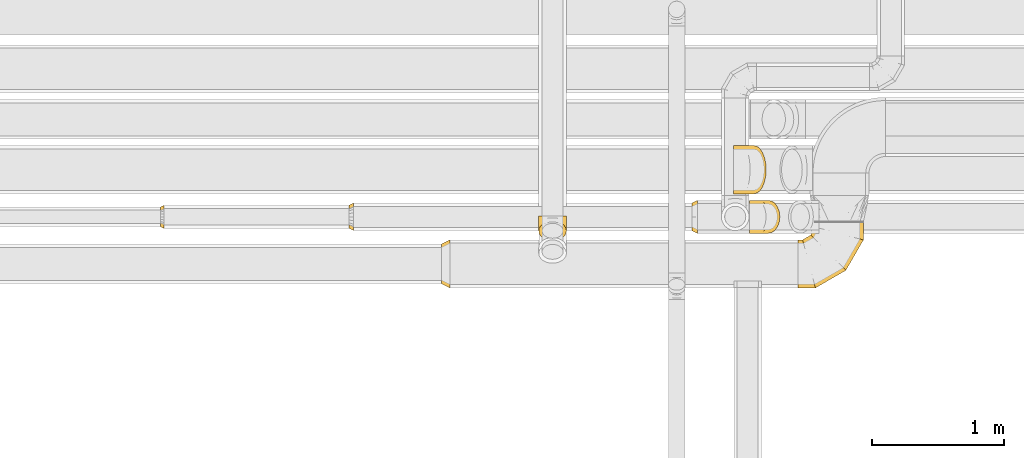
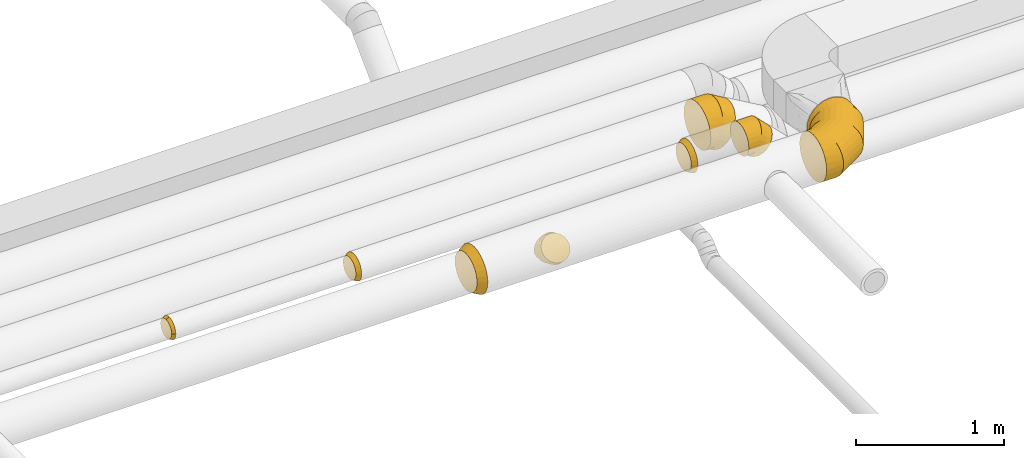
# One storey, part 17 of 92: 8 coverings.
"""IFC2X3 building model written with IfcOpenShell, lengths in millimetres."""

from ifc_helpers import new_model, entity, si_unit, converted_unit, derived_unit, direction, frame, origin, place, context, subcontext, project, spatial, faceted_brep, element, save


model = new_model("IFC2X3")

# Units and contexts
model_context = context("Model", 3, precision=0.01, world=origin(), true_north=direction((6.12303176911189e-17, 1.0)))
body_context = subcontext(model_context, "Body", "Model", "MODEL_VIEW")
ifc_project = project(units=[si_unit("LENGTHUNIT", "METRE", prefix="MILLI"), si_unit("AREAUNIT", "SQUARE_METRE"), si_unit("VOLUMEUNIT", "CUBIC_METRE"), converted_unit("PLANEANGLEUNIT", "DEGREE", entity("IfcRatioMeasure", 0.0174532925199433), si_unit("PLANEANGLEUNIT", "RADIAN"), dimensions=[0, 0, 0, 0, 0, 0, 0]), si_unit("MASSUNIT", "GRAM", prefix="KILO"), derived_unit("MASSDENSITYUNIT", [(si_unit("MASSUNIT", "GRAM", prefix="KILO"), 1), (si_unit("LENGTHUNIT", "METRE"), -3)]), derived_unit("MOMENTOFINERTIAUNIT", [(si_unit("LENGTHUNIT", "METRE"), 4)]), si_unit("TIMEUNIT", "SECOND"), si_unit("FREQUENCYUNIT", "HERTZ"), si_unit("THERMODYNAMICTEMPERATUREUNIT", "DEGREE_CELSIUS"), derived_unit("THERMALTRANSMITTANCEUNIT", [(si_unit("MASSUNIT", "GRAM", prefix="KILO"), 1), (si_unit("THERMODYNAMICTEMPERATUREUNIT", "KELVIN"), -1), (si_unit("TIMEUNIT", "SECOND"), -3)]), derived_unit("VOLUMETRICFLOWRATEUNIT", [(si_unit("LENGTHUNIT", "METRE"), 3), (si_unit("TIMEUNIT", "SECOND"), -1)]), derived_unit("MASSFLOWRATEUNIT", [(si_unit("MASSUNIT", "GRAM", prefix="KILO"), 1), (si_unit("TIMEUNIT", "SECOND"), -1)]), derived_unit("ROTATIONALFREQUENCYUNIT", [(si_unit("TIMEUNIT", "SECOND"), -1)]), si_unit("ELECTRICCURRENTUNIT", "AMPERE"), si_unit("ELECTRICVOLTAGEUNIT", "VOLT"), si_unit("POWERUNIT", "WATT"), si_unit("FORCEUNIT", "NEWTON", prefix="KILO"), si_unit("ILLUMINANCEUNIT", "LUX"), si_unit("LUMINOUSFLUXUNIT", "LUMEN"), si_unit("LUMINOUSINTENSITYUNIT", "CANDELA"), derived_unit("USERDEFINED", [(si_unit("MASSUNIT", "GRAM", prefix="KILO"), -1), (si_unit("LENGTHUNIT", "METRE"), -2), (si_unit("TIMEUNIT", "SECOND"), 3), (si_unit("LUMINOUSFLUXUNIT", "LUMEN"), 1)]), derived_unit("LINEARVELOCITYUNIT", [(si_unit("LENGTHUNIT", "METRE"), 1), (si_unit("TIMEUNIT", "SECOND"), -1)]), si_unit("PRESSUREUNIT", "PASCAL"), derived_unit("USERDEFINED", [(si_unit("LENGTHUNIT", "METRE"), -2), (si_unit("MASSUNIT", "GRAM", prefix="KILO"), 1), (si_unit("TIMEUNIT", "SECOND"), -2)]), derived_unit("LINEARFORCEUNIT", [(si_unit("MASSUNIT", "GRAM", prefix="KILO"), 1), (si_unit("LENGTHUNIT", "METRE"), 1), (si_unit("TIMEUNIT", "SECOND"), -2), (si_unit("LENGTHUNIT", "METRE"), -1)]), derived_unit("PLANARFORCEUNIT", [(si_unit("MASSUNIT", "GRAM", prefix="KILO"), 1), (si_unit("LENGTHUNIT", "METRE"), 1), (si_unit("TIMEUNIT", "SECOND"), -2), (si_unit("LENGTHUNIT", "METRE"), -2)])], contexts=[model_context])

# Site, building, storey
site_placement = place(None, origin())
site = spatial("IfcSite", under=ifc_project, at=site_placement, CompositionType="ELEMENT")
building_placement = place(site_placement, origin())
building = spatial("IfcBuilding", under=site, at=building_placement, CompositionType="ELEMENT")
storey_placement = place(building_placement, frame((0.0, 0.0, 4200.0)))
storey = spatial("IfcBuildingStorey", under=building, at=storey_placement, CompositionType="ELEMENT", Elevation=4200.0)

# Coverings
covering_1_placement = place(storey_placement, frame((44198.05, 14057.9, 3115.9)))
element("IfcCovering", 1, at=covering_1_placement, inside=storey, PredefinedType="INSULATION", context=body_context, shape_type="Brep", body=[
    faceted_brep([(0.0, 259.1, 314.0), (0.0, 290.16, 290.16), (0.0, 314.0, 259.1), (0.0, 328.98, 222.92), (0.0, 334.1, 184.1), (0.0, 328.98, 145.27), (0.0, 314.0, 109.1), (0.0, 290.16, 78.03), (0.0, 259.1, 54.19), (0.0, 222.92, 39.21), (0.0, 184.1, 34.1), (0.0, 145.27, 39.21), (0.0, 109.1, 54.19), (0.0, 78.03, 78.03), (0.0, 54.19, 109.1), (0.0, 39.21, 145.27), (0.0, 34.1, 184.1), (0.0, 39.21, 222.92), (0.0, 54.19, 259.1), (0.0, 78.03, 290.16), (0.0, 109.1, 314.0), (0.0, 145.27, 328.98), (0.0, 184.1, 334.1), (0.0, 222.92, 328.98), (65.0, 136.86, 360.38), (65.0, 92.85, 342.14), (65.0, 55.05, 313.14), (65.0, 26.05, 275.35), (65.0, 7.81, 231.33), (65.0, 1.6, 184.1), (65.0, 7.81, 136.86), (65.0, 26.05, 92.85), (65.0, 55.05, 55.05), (65.0, 92.85, 26.05), (65.0, 136.86, 7.81), (65.0, 184.1, 1.6), (65.0, 231.33, 7.81), (65.0, 275.35, 26.05), (65.0, 313.14, 55.05), (65.0, 342.14, 92.85), (65.0, 360.38, 136.86), (65.0, 366.6, 184.1), (65.0, 360.38, 231.33), (65.0, 342.14, 275.35), (65.0, 313.14, 313.14), (65.0, 275.35, 342.14), (65.0, 231.33, 360.38), (65.0, 184.1, 366.6)], [[[0, 1, 2, 3, 4, 5, 6, 7, 8, 9, 10, 11, 12, 13, 14, 15, 16, 17, 18, 19, 20, 21, 22, 23]], [[24, 25, 26, 27, 28, 29, 30, 31, 32, 33, 34, 35, 36, 37, 38, 39, 40, 41, 42, 43, 44, 45, 46, 47]], [[37, 36, 9, 8]], [[38, 37, 8, 7]], [[35, 10, 9, 36]], [[5, 4, 41, 40]], [[6, 5, 40, 39]], [[39, 38, 7, 6]], [[31, 30, 15, 14]], [[32, 31, 14, 13]], [[29, 16, 15, 30]], [[11, 10, 35, 34]], [[12, 11, 34, 33]], [[33, 32, 13, 12]], [[25, 24, 21, 20]], [[26, 25, 20, 19]], [[47, 22, 21, 24]], [[17, 16, 29, 28]], [[18, 17, 28, 27]], [[27, 26, 19, 18]], [[43, 42, 3, 2]], [[44, 43, 2, 1]], [[41, 4, 3, 42]], [[23, 22, 47, 46]], [[0, 23, 46, 45]], [[45, 44, 1, 0]]]),
])
covering_2_placement = place(storey_placement, frame((46905.11, 14057.9, 3115.9)))
element("IfcCovering", 2, at=covering_2_placement, inside=storey, PredefinedType="INSULATION", context=body_context, shape_type="Brep", body=[
    faceted_brep([(491.28, 499.1, 231.33), (497.5, 499.1, 184.1), (491.28, 499.1, 136.86), (473.05, 499.1, 92.85), (444.05, 499.1, 55.05), (406.25, 499.1, 26.05), (362.23, 499.1, 7.81), (315.0, 499.1, 1.6), (267.77, 499.1, 7.81), (223.75, 499.1, 26.05), (185.95, 499.1, 55.05), (156.95, 499.1, 92.85), (138.72, 499.1, 136.86), (132.5, 499.1, 184.1), (138.72, 499.1, 231.33), (156.95, 499.1, 275.35), (185.95, 499.1, 313.14), (223.75, 499.1, 342.14), (267.77, 499.1, 360.38), (315.0, 499.1, 366.6), (362.23, 499.1, 360.38), (406.25, 499.1, 342.14), (444.05, 499.1, 313.14), (473.05, 499.1, 275.35), (0.0, 26.05, 92.85), (0.0, 7.81, 136.86), (0.0, 1.6, 184.1), (0.0, 7.81, 231.33), (0.0, 26.05, 275.35), (0.0, 55.05, 313.14), (0.0, 92.85, 342.14), (0.0, 136.86, 360.38), (0.0, 184.1, 366.6), (0.0, 231.33, 360.38), (0.0, 275.35, 342.14), (0.0, 313.14, 313.14), (0.0, 342.14, 275.35), (0.0, 360.38, 231.33), (0.0, 366.6, 184.1), (0.0, 360.38, 136.86), (0.0, 342.14, 92.85), (0.0, 313.14, 55.05), (0.0, 275.35, 26.05), (0.0, 231.33, 7.81), (0.0, 184.1, 1.6), (0.0, 136.86, 7.81), (0.0, 92.85, 26.05), (0.0, 55.05, 55.05), (133.3, 1.6, 184.1), (132.08, 6.17, 224.71), (128.46, 19.67, 263.28), (122.64, 41.41, 297.88), (114.89, 70.31, 326.78), (105.62, 104.91, 348.52), (95.29, 143.49, 362.02), (84.4, 184.1, 366.6), (73.52, 224.71, 362.02), (63.19, 263.28, 348.52), (53.91, 297.88, 326.78), (46.17, 326.78, 297.88), (40.35, 348.52, 263.28), (36.73, 362.02, 224.71), (35.5, 366.6, 184.1), (40.35, 348.52, 104.91), (46.17, 326.78, 70.31), (36.73, 362.02, 143.49), (53.91, 297.88, 41.41), (63.19, 263.28, 19.67), (73.52, 224.71, 6.17), (84.4, 184.1, 1.6), (95.29, 143.49, 6.17), (105.62, 104.91, 19.67), (114.89, 70.31, 41.41), (122.64, 41.41, 70.31), (128.46, 19.67, 104.91), (132.08, 6.17, 143.49), (364.2, 134.9, 184.1), (360.85, 138.25, 224.71), (350.96, 148.13, 263.28), (335.05, 164.05, 297.88), (313.89, 185.2, 326.78), (288.56, 210.53, 348.52), (260.32, 238.77, 362.02), (230.6, 268.5, 366.6), (200.87, 298.23, 362.02), (172.63, 326.47, 348.52), (147.3, 351.8, 326.78), (126.14, 372.95, 297.88), (110.23, 388.87, 263.28), (100.35, 398.75, 224.71), (97.0, 402.1, 184.1), (100.35, 398.75, 143.49), (110.23, 388.87, 104.91), (126.14, 372.95, 70.31), (147.3, 351.8, 41.41), (172.63, 326.47, 19.67), (200.87, 298.23, 6.17), (230.6, 268.5, 1.6), (260.32, 238.77, 6.17), (288.56, 210.53, 19.67), (313.89, 185.2, 41.41), (335.05, 164.05, 70.31), (350.96, 148.13, 104.91), (360.85, 138.25, 143.49), (497.5, 365.79, 184.1), (492.92, 367.02, 224.71), (479.43, 370.63, 263.28), (457.68, 376.46, 297.88), (428.79, 384.2, 326.78), (394.18, 393.47, 348.52), (355.61, 403.81, 362.02), (315.0, 414.69, 366.6), (274.39, 425.57, 362.02), (235.82, 435.91, 348.52), (201.21, 445.18, 326.78), (172.32, 452.92, 297.88), (150.57, 458.75, 263.28), (137.08, 462.37, 224.71), (132.5, 463.59, 184.1), (137.08, 462.37, 143.49), (150.57, 458.75, 104.91), (172.32, 452.92, 70.31), (201.21, 445.18, 41.41), (235.82, 435.91, 19.67), (274.39, 425.57, 6.17), (315.0, 414.69, 1.6), (355.61, 403.81, 6.17), (394.18, 393.47, 19.67), (428.79, 384.2, 41.41), (457.68, 376.46, 70.31), (479.43, 370.63, 104.91), (492.92, 367.02, 143.49)], [[[0, 1, 2, 3, 4, 5, 6, 7, 8, 9, 10, 11, 12, 13, 14, 15, 16, 17, 18, 19, 20, 21, 22, 23]], [[24, 25, 26, 27, 28, 29, 30, 31, 32, 33, 34, 35, 36, 37, 38, 39, 40, 41, 42, 43, 44, 45, 46, 47]], [[26, 48, 49]], [[27, 49, 50]], [[26, 49, 27]], [[28, 51, 29]], [[28, 27, 50]], [[51, 28, 50]], [[30, 52, 53]], [[31, 53, 54]], [[32, 54, 55]], [[29, 52, 30]], [[30, 53, 31]], [[54, 32, 31]], [[52, 29, 51]], [[56, 57, 33]], [[55, 56, 32]], [[32, 56, 33]], [[34, 58, 35]], [[34, 33, 57]], [[58, 34, 57]], [[59, 60, 36]], [[61, 62, 38]], [[60, 61, 37]], [[35, 59, 36]], [[36, 60, 37]], [[61, 38, 37]], [[59, 35, 58]], [[63, 64, 40]], [[65, 63, 39]], [[62, 65, 38]], [[38, 65, 39]], [[63, 40, 39]], [[64, 41, 40]], [[66, 67, 42]], [[68, 69, 44]], [[67, 68, 43]], [[41, 66, 42]], [[42, 67, 43]], [[68, 44, 43]], [[66, 41, 64]], [[45, 70, 71]], [[46, 71, 72]], [[69, 70, 44]], [[44, 70, 45]], [[71, 46, 45]], [[72, 47, 46]], [[24, 73, 74]], [[74, 75, 25]], [[48, 26, 75]], [[47, 73, 24]], [[24, 74, 25]], [[75, 26, 25]], [[73, 47, 72]], [[49, 48, 76, 77]], [[49, 77, 78, 50]], [[51, 50, 78, 79]], [[79, 80, 52, 51]], [[53, 52, 80, 81]], [[54, 53, 81, 82]], [[55, 54, 82, 83]], [[83, 84, 56, 55]], [[85, 86, 58, 57]], [[84, 85, 57, 56]], [[86, 87, 59, 58]], [[87, 88, 60, 59]], [[89, 90, 62, 61]], [[88, 89, 61, 60]], [[90, 91, 65, 62]], [[92, 93, 64, 63]], [[91, 92, 63, 65]], [[93, 94, 66, 64]], [[94, 95, 67, 66]], [[96, 97, 69, 68]], [[95, 96, 68, 67]], [[70, 69, 97, 98]], [[98, 99, 71, 70]], [[100, 72, 71, 99]], [[100, 101, 73, 72]], [[74, 73, 101, 102]], [[102, 103, 75, 74]], [[76, 48, 75, 103]], [[77, 76, 104, 105]], [[77, 105, 106, 78]], [[79, 78, 106, 107]], [[107, 108, 80, 79]], [[81, 80, 108, 109]], [[82, 81, 109, 110]], [[83, 82, 110, 111]], [[111, 112, 84, 83]], [[113, 114, 86, 85]], [[112, 113, 85, 84]], [[114, 115, 87, 86]], [[115, 116, 88, 87]], [[117, 118, 90, 89]], [[116, 117, 89, 88]], [[118, 119, 91, 90]], [[120, 121, 93, 92]], [[119, 120, 92, 91]], [[121, 122, 94, 93]], [[122, 123, 95, 94]], [[124, 125, 97, 96]], [[123, 124, 96, 95]], [[98, 97, 125, 126]], [[126, 127, 99, 98]], [[128, 100, 99, 127]], [[128, 129, 101, 100]], [[102, 101, 129, 130]], [[130, 131, 103, 102]], [[104, 76, 103, 131]], [[105, 1, 0]], [[106, 0, 23]], [[104, 1, 105]], [[105, 0, 106]], [[23, 107, 106]], [[23, 22, 107]], [[108, 22, 21]], [[109, 21, 20]], [[110, 20, 19]], [[108, 21, 109]], [[109, 20, 110]], [[19, 111, 110]], [[22, 108, 107]], [[112, 19, 18]], [[113, 18, 17]], [[112, 111, 19]], [[114, 113, 17]], [[112, 18, 113]], [[17, 16, 114]], [[115, 16, 15]], [[116, 15, 14]], [[117, 14, 13]], [[116, 115, 15]], [[118, 117, 13]], [[116, 14, 117]], [[16, 115, 114]], [[119, 13, 12]], [[120, 12, 11]], [[119, 118, 13]], [[121, 120, 11]], [[119, 12, 120]], [[11, 10, 121]], [[122, 10, 9]], [[123, 9, 8]], [[124, 8, 7]], [[123, 122, 9]], [[125, 124, 7]], [[123, 8, 124]], [[10, 122, 121]], [[126, 7, 6]], [[127, 6, 5]], [[125, 7, 126]], [[127, 126, 6]], [[128, 127, 5]], [[5, 4, 128]], [[129, 4, 3]], [[130, 3, 2]], [[131, 2, 1]], [[129, 3, 130]], [[131, 130, 2]], [[104, 131, 1]], [[4, 129, 128]]]),
])
covering_3_placement = place(storey_placement, frame((46101.01, 14472.9, 3232.89)))
element("IfcCovering", 3, at=covering_3_placement, inside=storey, PredefinedType="INSULATION", context=body_context, shape_type="Brep", body=[
    faceted_brep([(0.0, 94.15, 226.46), (0.0, 126.6, 231.6), (0.0, 159.04, 226.46), (0.0, 188.31, 211.54), (0.0, 211.54, 188.31), (0.0, 226.46, 159.04), (0.0, 231.6, 126.6), (0.0, 226.46, 94.15), (0.0, 211.54, 64.88), (0.0, 188.31, 41.65), (0.0, 159.04, 26.73), (0.0, 126.6, 21.6), (0.0, 94.15, 26.73), (0.0, 64.88, 41.65), (0.0, 41.65, 64.88), (0.0, 26.73, 94.15), (0.0, 21.6, 126.6), (0.0, 26.73, 159.04), (0.0, 41.65, 188.31), (0.0, 64.88, 211.54), (40.0, 1.6, 126.6), (40.0, 7.71, 87.97), (40.0, 25.47, 53.12), (40.0, 53.12, 25.47), (40.0, 87.97, 7.71), (40.0, 126.6, 1.6), (40.0, 165.22, 7.71), (40.0, 200.07, 25.47), (40.0, 227.72, 53.12), (40.0, 245.48, 87.97), (40.0, 251.6, 126.6), (40.0, 245.48, 165.22), (40.0, 227.72, 200.07), (40.0, 200.07, 227.72), (40.0, 165.22, 245.48), (40.0, 126.6, 251.6), (40.0, 87.97, 245.48), (40.0, 53.12, 227.72), (40.0, 25.47, 200.07), (40.0, 7.71, 165.22)], [[[0, 1, 2, 3, 4, 5, 6, 7, 8, 9, 10, 11, 12, 13, 14, 15, 16, 17, 18, 19]], [[20, 21, 22, 23, 24, 25, 26, 27, 28, 29, 30, 31, 32, 33, 34, 35, 36, 37, 38, 39]], [[26, 25, 11, 10]], [[26, 10, 9, 27]], [[9, 8, 28, 27]], [[7, 6, 30, 29]], [[8, 7, 29, 28]], [[21, 20, 16, 15]], [[21, 15, 14, 22]], [[14, 13, 23, 22]], [[12, 11, 25, 24]], [[13, 12, 24, 23]], [[36, 35, 1, 0]], [[36, 0, 19, 37]], [[19, 18, 38, 37]], [[17, 16, 20, 39]], [[18, 17, 39, 38]], [[31, 30, 6, 5]], [[31, 5, 4, 32]], [[4, 3, 33, 32]], [[2, 1, 35, 34]], [[3, 2, 34, 33]]]),
])
covering_4_placement = place(storey_placement, frame((43496.01, 14492.9, 3252.89)))
element("IfcCovering", 4, at=covering_4_placement, inside=storey, PredefinedType="INSULATION", context=body_context, shape_type="Brep", body=[
    faceted_brep([(0.0, 79.56, 189.81), (0.0, 106.6, 194.1), (0.0, 133.63, 189.81), (0.0, 158.03, 177.38), (0.0, 177.38, 158.03), (0.0, 189.81, 133.63), (0.0, 194.1, 106.6), (0.0, 189.81, 79.56), (0.0, 177.38, 55.16), (0.0, 158.03, 35.81), (0.0, 133.63, 23.38), (0.0, 106.6, 19.1), (0.0, 79.56, 23.38), (0.0, 55.16, 35.81), (0.0, 35.81, 55.16), (0.0, 23.38, 79.56), (0.0, 19.1, 106.6), (0.0, 23.38, 133.63), (0.0, 35.81, 158.03), (0.0, 55.16, 177.38), (35.0, 1.6, 106.6), (35.0, 6.73, 74.15), (35.0, 21.65, 44.88), (35.0, 44.88, 21.65), (35.0, 74.15, 6.73), (35.0, 106.6, 1.6), (35.0, 139.04, 6.73), (35.0, 168.31, 21.65), (35.0, 191.54, 44.88), (35.0, 206.46, 74.15), (35.0, 211.6, 106.6), (35.0, 206.46, 139.04), (35.0, 191.54, 168.31), (35.0, 168.31, 191.54), (35.0, 139.04, 206.46), (35.0, 106.6, 211.6), (35.0, 74.15, 206.46), (35.0, 44.88, 191.54), (35.0, 21.65, 168.31), (35.0, 6.73, 139.04)], [[[0, 1, 2, 3, 4, 5, 6, 7, 8, 9, 10, 11, 12, 13, 14, 15, 16, 17, 18, 19]], [[20, 21, 22, 23, 24, 25, 26, 27, 28, 29, 30, 31, 32, 33, 34, 35, 36, 37, 38, 39]], [[26, 25, 11, 10]], [[26, 10, 9, 27]], [[9, 8, 28, 27]], [[7, 6, 30, 29]], [[8, 7, 29, 28]], [[21, 20, 16, 15]], [[21, 15, 14, 22]], [[14, 13, 23, 22]], [[12, 11, 25, 24]], [[13, 12, 24, 23]], [[36, 35, 1, 0]], [[36, 0, 19, 37]], [[19, 18, 38, 37]], [[17, 16, 20, 39]], [[18, 17, 39, 38]], [[31, 30, 6, 5]], [[31, 5, 4, 32]], [[4, 3, 33, 32]], [[2, 1, 35, 34]], [[3, 2, 34, 33]]]),
])
covering_5_placement = place(storey_placement, frame((46538.41, 14472.9, 3210.92)))
element("IfcCovering", 5, at=covering_5_placement, inside=storey, PredefinedType="INSULATION", context=body_context, shape_type="Brep", body=[
    faceted_brep([(53.03, 126.6, 1.6), (57.36, 165.22, 5.92), (69.91, 200.07, 18.48), (89.47, 227.72, 38.03), (114.11, 245.48, 62.67), (141.42, 251.6, 89.98), (168.73, 245.48, 117.3), (193.37, 227.72, 141.94), (212.93, 200.07, 161.49), (225.48, 165.22, 174.05), (229.81, 126.6, 178.37), (225.48, 87.97, 174.05), (212.93, 53.12, 161.49), (193.37, 25.47, 141.94), (168.73, 7.71, 117.3), (141.42, 1.6, 89.98), (114.11, 7.71, 62.67), (89.47, 25.47, 38.03), (69.91, 53.12, 18.48), (57.36, 87.97, 5.92), (0.0, 94.24, 269.3), (0.0, 126.6, 273.56), (0.0, 158.95, 269.3), (0.0, 189.1, 256.82), (0.0, 214.98, 236.95), (0.0, 234.85, 211.06), (0.0, 247.34, 180.91), (0.0, 251.6, 148.56), (0.0, 247.34, 116.21), (0.0, 234.85, 86.06), (0.0, 214.98, 60.17), (0.0, 189.1, 40.31), (0.0, 158.95, 27.82), (0.0, 126.6, 23.56), (0.0, 94.24, 27.82), (0.0, 64.1, 40.31), (0.0, 38.21, 60.17), (0.0, 18.34, 86.06), (0.0, 5.85, 116.21), (0.0, 1.6, 148.56), (0.0, 5.85, 180.91), (0.0, 18.34, 211.06), (0.0, 38.21, 236.95), (0.0, 64.1, 256.82), (134.62, 126.6, 273.56), (132.86, 158.95, 269.3), (127.68, 189.1, 256.82), (119.45, 214.98, 236.95), (108.73, 234.85, 211.06), (96.24, 247.34, 180.91), (82.84, 251.6, 148.56), (69.44, 247.34, 116.21), (56.95, 234.85, 86.06), (46.23, 214.98, 60.17), (32.83, 158.95, 27.82), (31.07, 126.6, 23.56), (38.0, 189.1, 40.31), (38.0, 64.1, 40.31), (46.23, 38.21, 60.17), (32.83, 94.24, 27.82), (69.44, 5.85, 116.21), (82.84, 1.6, 148.56), (56.95, 18.34, 86.06), (96.24, 5.85, 180.91), (108.73, 18.34, 211.06), (119.45, 38.21, 236.95), (127.68, 64.1, 256.82), (132.86, 94.24, 269.3)], [[[0, 1, 2, 3, 4, 5, 6, 7, 8, 9, 10, 11, 12, 13, 14, 15, 16, 17, 18, 19]], [[20, 21, 22, 23, 24, 25, 26, 27, 28, 29, 30, 31, 32, 33, 34, 35, 36, 37, 38, 39, 40, 41, 42, 43]], [[21, 44, 45, 22]], [[22, 45, 46, 23]], [[47, 24, 23, 46]], [[24, 47, 48, 25]], [[25, 48, 49, 26]], [[50, 27, 26, 49]], [[51, 52, 29, 28]], [[50, 51, 28, 27]], [[29, 52, 53, 30]], [[54, 55, 33, 32]], [[56, 54, 32, 31]], [[30, 53, 56, 31]], [[35, 57, 58, 36]], [[59, 57, 35, 34]], [[33, 55, 59, 34]], [[60, 61, 39, 38]], [[62, 60, 38, 37]], [[58, 62, 37, 36]], [[40, 39, 61, 63]], [[41, 40, 63, 64]], [[64, 65, 42, 41]], [[20, 43, 66, 67]], [[21, 20, 67, 44]], [[65, 66, 43, 42]], [[9, 8, 46]], [[10, 9, 45]], [[10, 45, 44]], [[45, 9, 46]], [[8, 47, 46]], [[48, 7, 6]], [[49, 6, 5]], [[47, 7, 48]], [[48, 6, 49]], [[5, 50, 49]], [[7, 47, 8]], [[4, 3, 52]], [[5, 4, 51]], [[51, 50, 5]], [[52, 51, 4]], [[3, 53, 52]], [[56, 2, 1]], [[54, 1, 0]], [[56, 53, 2]], [[55, 54, 0]], [[56, 1, 54]], [[2, 53, 3]], [[19, 18, 57]], [[0, 19, 59]], [[59, 55, 0]], [[57, 59, 19]], [[18, 58, 57]], [[62, 17, 16]], [[60, 16, 15]], [[62, 58, 17]], [[61, 60, 15]], [[62, 16, 60]], [[17, 58, 18]], [[63, 15, 14]], [[64, 14, 13]], [[15, 63, 61]], [[63, 14, 64]], [[13, 65, 64]], [[66, 12, 11]], [[67, 11, 10]], [[65, 12, 66]], [[67, 66, 11]], [[44, 67, 10]], [[12, 65, 13]]]),
])
covering_6_placement = place(storey_placement, frame((42066.01, 14510.4, 3270.39)))
element("IfcCovering", 6, at=covering_6_placement, inside=storey, PredefinedType="INSULATION", context=body_context, shape_type="Brep", body=[
    faceted_brep([(0.0, 60.39, 158.39), (0.0, 74.74, 161.24), (0.0, 89.1, 164.1), (0.0, 103.45, 161.24), (0.0, 117.8, 158.39), (0.0, 129.96, 150.26), (0.0, 142.13, 142.13), (0.0, 150.26, 129.96), (0.0, 158.39, 117.8), (0.0, 161.24, 103.45), (0.0, 164.1, 89.1), (0.0, 161.24, 74.74), (0.0, 158.39, 60.39), (0.0, 150.26, 48.23), (0.0, 142.13, 36.06), (0.0, 129.96, 27.93), (0.0, 117.8, 19.8), (0.0, 103.45, 16.95), (0.0, 89.1, 14.1), (0.0, 74.74, 16.95), (0.0, 60.39, 19.8), (0.0, 48.23, 27.93), (0.0, 36.06, 36.06), (0.0, 27.93, 48.23), (0.0, 19.8, 60.39), (0.0, 16.95, 74.74), (0.0, 14.1, 89.1), (0.0, 16.95, 103.45), (0.0, 19.8, 117.8), (0.0, 27.93, 129.96), (0.0, 36.06, 142.13), (0.0, 48.23, 150.26), (25.0, 1.6, 89.1), (25.0, 5.88, 62.06), (25.0, 18.31, 37.66), (25.0, 37.66, 18.31), (25.0, 62.06, 5.88), (25.0, 89.1, 1.6), (25.0, 116.13, 5.88), (25.0, 140.53, 18.31), (25.0, 159.88, 37.66), (25.0, 172.31, 62.06), (25.0, 176.6, 89.1), (25.0, 172.31, 116.13), (25.0, 159.88, 140.53), (25.0, 140.53, 159.88), (25.0, 116.13, 172.31), (25.0, 89.1, 176.6), (25.0, 62.06, 172.31), (25.0, 37.66, 159.88), (25.0, 18.31, 140.53), (25.0, 5.88, 116.13)], [[[0, 1, 2, 3, 4, 5, 6, 7, 8, 9, 10, 11, 12, 13, 14, 15, 16, 17, 18, 19, 20, 21, 22, 23, 24, 25, 26, 27, 28, 29, 30, 31]], [[32, 33, 34, 35, 36, 37, 38, 39, 40, 41, 42, 43, 44, 45, 46, 47, 48, 49, 50, 51]], [[37, 17, 38]], [[17, 37, 18]], [[16, 39, 38]], [[41, 12, 11]], [[17, 16, 38]], [[39, 16, 15, 14]], [[40, 14, 13, 12]], [[42, 11, 10]], [[41, 40, 12]], [[42, 41, 11]], [[14, 40, 39]], [[32, 25, 33]], [[25, 32, 26]], [[24, 34, 33]], [[36, 20, 19]], [[25, 24, 33]], [[34, 24, 23, 22]], [[35, 22, 21, 20]], [[37, 19, 18]], [[36, 35, 20]], [[37, 36, 19]], [[22, 35, 34]], [[47, 1, 48]], [[1, 47, 2]], [[0, 49, 48]], [[51, 28, 27]], [[1, 0, 48]], [[49, 0, 31, 30]], [[50, 30, 29, 28]], [[32, 27, 26]], [[51, 50, 28]], [[32, 51, 27]], [[30, 50, 49]], [[42, 9, 43]], [[9, 42, 10]], [[8, 44, 43]], [[46, 4, 3]], [[9, 8, 43]], [[44, 8, 7, 6]], [[45, 6, 5, 4]], [[47, 3, 2]], [[46, 45, 4]], [[47, 46, 3]], [[6, 45, 44]]]),
])
covering_7_placement = place(storey_placement, frame((46415.27, 14772.9, 3098.15)))
element("IfcCovering", 7, at=covering_7_placement, inside=storey, PredefinedType="INSULATION", context=body_context, shape_type="Brep", body=[
    faceted_brep([(0.0, 184.1, 19.35), (0.0, 136.86, 25.57), (0.0, 92.85, 43.8), (0.0, 55.05, 72.8), (0.0, 26.05, 110.6), (0.0, 7.81, 154.61), (0.0, 1.6, 201.85), (0.0, 7.81, 249.08), (0.0, 26.05, 293.1), (0.0, 55.05, 330.89), (0.0, 92.85, 359.9), (0.0, 136.86, 378.13), (0.0, 184.1, 384.35), (0.0, 231.33, 378.13), (0.0, 275.35, 359.9), (0.0, 313.14, 330.89), (0.0, 342.14, 293.1), (0.0, 360.38, 249.08), (0.0, 366.6, 201.85), (0.0, 360.38, 154.61), (0.0, 342.14, 110.6), (0.0, 313.14, 72.8), (0.0, 275.35, 43.8), (0.0, 231.33, 25.57), (236.52, 275.35, 296.52), (245.64, 231.33, 312.31), (248.75, 184.1, 317.69), (245.64, 136.86, 312.31), (236.52, 92.85, 296.52), (222.02, 55.05, 271.4), (203.13, 26.05, 238.67), (181.12, 7.81, 200.55), (157.5, 1.6, 159.64), (133.88, 7.81, 118.74), (111.88, 26.05, 80.62), (92.98, 55.05, 47.89), (78.48, 92.85, 22.77), (69.36, 136.86, 6.98), (66.25, 184.1, 1.6), (69.36, 231.33, 6.98), (78.48, 275.35, 22.77), (92.98, 313.14, 47.89), (111.88, 342.14, 80.62), (133.88, 360.38, 118.74), (157.5, 366.6, 159.64), (181.12, 360.38, 200.55), (203.13, 342.14, 238.67), (222.02, 313.14, 271.4), (133.3, 184.1, 384.35), (132.08, 143.49, 379.77), (128.46, 104.91, 366.27), (122.64, 70.31, 344.53), (114.89, 41.41, 315.63), (105.62, 19.67, 281.03), (95.29, 6.17, 242.46), (84.4, 1.6, 201.85), (73.52, 6.17, 161.24), (63.19, 19.67, 122.66), (53.91, 41.41, 88.06), (46.17, 70.31, 59.16), (40.35, 104.91, 37.42), (36.73, 143.49, 23.92), (35.5, 184.1, 19.35), (40.35, 263.28, 37.42), (46.17, 297.88, 59.16), (36.73, 224.71, 23.92), (53.91, 326.78, 88.06), (63.19, 348.52, 122.66), (73.52, 362.02, 161.24), (84.4, 366.6, 201.85), (95.29, 362.02, 242.46), (105.62, 348.52, 281.03), (114.89, 326.78, 315.63), (122.64, 297.88, 344.53), (128.46, 263.28, 366.27), (132.08, 224.71, 379.77)], [[[0, 1, 2, 3, 4, 5, 6, 7, 8, 9, 10, 11, 12, 13, 14, 15, 16, 17, 18, 19, 20, 21, 22, 23]], [[24, 25, 26, 27, 28, 29, 30, 31, 32, 33, 34, 35, 36, 37, 38, 39, 40, 41, 42, 43, 44, 45, 46, 47]], [[26, 48, 49]], [[27, 49, 50]], [[26, 49, 27]], [[28, 51, 29]], [[28, 27, 50]], [[51, 28, 50]], [[30, 52, 53]], [[31, 53, 54]], [[32, 54, 55]], [[29, 52, 30]], [[30, 53, 31]], [[54, 32, 31]], [[52, 29, 51]], [[56, 57, 33]], [[55, 56, 32]], [[32, 56, 33]], [[34, 58, 35]], [[34, 33, 57]], [[58, 34, 57]], [[59, 60, 36]], [[61, 62, 38]], [[60, 61, 37]], [[35, 59, 36]], [[36, 60, 37]], [[61, 38, 37]], [[59, 35, 58]], [[63, 64, 40]], [[65, 63, 39]], [[62, 65, 38]], [[38, 65, 39]], [[63, 40, 39]], [[64, 41, 40]], [[66, 67, 42]], [[68, 69, 44]], [[67, 68, 43]], [[41, 66, 42]], [[42, 67, 43]], [[68, 44, 43]], [[66, 41, 64]], [[45, 70, 71]], [[46, 71, 72]], [[69, 70, 44]], [[44, 70, 45]], [[71, 46, 45]], [[72, 47, 46]], [[24, 73, 74]], [[74, 75, 25]], [[48, 26, 75]], [[47, 73, 24]], [[24, 74, 25]], [[75, 26, 25]], [[73, 47, 72]], [[49, 12, 11]], [[50, 11, 10]], [[48, 12, 49]], [[49, 11, 50]], [[10, 51, 50]], [[10, 9, 51]], [[52, 9, 8]], [[53, 8, 7]], [[54, 7, 6]], [[52, 8, 53]], [[53, 7, 54]], [[6, 55, 54]], [[9, 52, 51]], [[56, 6, 5]], [[57, 5, 4]], [[56, 55, 6]], [[58, 57, 4]], [[56, 5, 57]], [[4, 3, 58]], [[59, 3, 2]], [[60, 2, 1]], [[61, 1, 0]], [[60, 59, 2]], [[62, 61, 0]], [[60, 1, 61]], [[3, 59, 58]], [[65, 0, 23]], [[63, 23, 22]], [[65, 62, 0]], [[64, 63, 22]], [[65, 23, 63]], [[22, 21, 64]], [[66, 21, 20]], [[67, 20, 19]], [[68, 19, 18]], [[67, 66, 20]], [[69, 68, 18]], [[67, 19, 68]], [[21, 66, 64]], [[70, 18, 17]], [[71, 17, 16]], [[69, 18, 70]], [[71, 70, 17]], [[72, 71, 16]], [[16, 15, 72]], [[73, 15, 14]], [[74, 14, 13]], [[75, 13, 12]], [[73, 14, 74]], [[75, 74, 13]], [[48, 75, 12]], [[15, 73, 72]]]),
])
covering_8_placement = place(storey_placement, frame((44935.71, 14416.84, 2893.4)))
element("IfcCovering", 8, at=covering_8_placement, inside=storey, PredefinedType="INSULATION", context=body_context, shape_type="Brep", body=[
    faceted_brep([(106.6, 189.64, 211.6), (139.04, 189.64, 206.46), (168.31, 189.64, 191.54), (191.54, 189.64, 168.31), (206.46, 189.64, 139.04), (211.6, 189.64, 106.6), (206.46, 189.64, 74.15), (191.54, 189.64, 44.88), (168.31, 189.64, 21.65), (139.04, 189.64, 6.73), (106.6, 189.64, 1.6), (74.15, 189.64, 6.73), (44.88, 189.64, 21.65), (21.65, 189.64, 44.88), (6.73, 189.64, 74.15), (1.6, 189.64, 106.6), (6.73, 189.64, 139.04), (21.65, 189.64, 168.31), (44.88, 189.64, 191.54), (74.15, 189.64, 206.46), (54.1, 11.58, 89.79), (79.42, 4.13, 82.4), (106.6, 1.6, 79.88), (133.77, 4.13, 82.4), (159.1, 11.58, 89.79), (180.84, 23.42, 101.55), (197.53, 38.85, 116.87), (208.02, 56.82, 134.71), (211.6, 76.1, 153.86), (208.02, 95.39, 173.01), (197.53, 113.36, 190.85), (180.84, 128.79, 206.17), (159.1, 140.63, 217.93), (133.77, 148.08, 225.32), (106.6, 150.61, 227.84), (79.42, 148.08, 225.32), (54.1, 140.63, 217.93), (32.35, 128.79, 206.17), (15.66, 113.36, 190.85), (5.17, 95.39, 173.01), (1.6, 76.1, 153.86), (5.17, 56.82, 134.71), (15.66, 38.85, 116.87), (32.35, 23.42, 101.55), (106.6, 38.91, 42.3), (133.77, 40.94, 45.33), (159.1, 46.91, 54.21), (180.84, 56.4, 68.33), (197.53, 68.77, 86.74), (208.02, 83.18, 108.17), (211.6, 98.63, 131.17), (208.02, 114.09, 154.17), (197.53, 128.5, 175.61), (180.84, 140.87, 194.01), (133.77, 156.32, 217.02), (106.6, 158.36, 220.04), (159.1, 150.36, 208.14), (54.1, 150.36, 208.14), (32.35, 140.87, 194.01), (79.42, 156.32, 217.02), (5.17, 114.09, 154.17), (1.6, 98.63, 131.17), (15.66, 128.5, 175.61), (5.17, 83.18, 108.17), (15.66, 68.77, 86.74), (32.35, 56.4, 68.33), (54.1, 46.91, 54.21), (79.42, 40.94, 45.33), (106.6, 136.69, 1.6), (133.77, 137.4, 5.17), (159.1, 139.5, 15.66), (180.84, 142.83, 32.35), (197.53, 147.18, 54.1), (208.02, 152.24, 79.42), (211.6, 157.67, 106.6), (208.02, 163.1, 133.77), (197.53, 168.16, 159.1), (180.84, 172.51, 180.84), (159.1, 175.84, 197.53), (133.77, 177.94, 208.02), (106.6, 178.65, 211.6), (79.42, 177.94, 208.02), (54.1, 175.84, 197.53), (32.35, 172.51, 180.84), (5.17, 163.1, 133.77), (1.6, 157.67, 106.6), (15.66, 168.16, 159.1), (5.17, 152.24, 79.42), (15.66, 147.18, 54.1), (32.35, 142.83, 32.35), (54.1, 139.5, 15.66), (79.42, 137.4, 5.17)], [[[0, 1, 2, 3, 4, 5, 6, 7, 8, 9, 10, 11, 12, 13, 14, 15, 16, 17, 18, 19]], [[20, 21, 22, 23, 24, 25, 26, 27, 28, 29, 30, 31, 32, 33, 34, 35, 36, 37, 38, 39, 40, 41, 42, 43]], [[22, 44, 45, 23]], [[23, 45, 46, 24]], [[24, 46, 47, 25]], [[26, 48, 49, 27]], [[27, 49, 50, 28]], [[26, 25, 47, 48]], [[51, 52, 30, 29]], [[50, 51, 29, 28]], [[30, 52, 53, 31]], [[54, 55, 34, 33]], [[56, 54, 33, 32]], [[31, 53, 56, 32]], [[36, 57, 58, 37]], [[59, 57, 36, 35]], [[34, 55, 59, 35]], [[60, 61, 40, 39]], [[62, 60, 39, 38]], [[58, 62, 38, 37]], [[42, 41, 63, 64]], [[43, 42, 64, 65]], [[40, 61, 63, 41]], [[21, 20, 66, 67]], [[22, 21, 67, 44]], [[65, 66, 20, 43]], [[45, 44, 68, 69]], [[46, 45, 69, 70]], [[70, 71, 47, 46]], [[48, 47, 71, 72]], [[49, 48, 72, 73]], [[50, 49, 73, 74]], [[75, 76, 52, 51]], [[74, 75, 51, 50]], [[53, 52, 76, 77]], [[78, 79, 54, 56]], [[77, 78, 56, 53]], [[55, 54, 79, 80]], [[81, 82, 57, 59]], [[80, 81, 59, 55]], [[58, 57, 82, 83]], [[84, 85, 61, 60]], [[86, 84, 60, 62]], [[83, 86, 62, 58]], [[63, 61, 85, 87]], [[64, 63, 87, 88]], [[65, 64, 88, 89]], [[67, 66, 90, 91]], [[44, 67, 91, 68]], [[89, 90, 66, 65]], [[69, 10, 9]], [[70, 9, 8]], [[10, 69, 68]], [[69, 9, 70]], [[8, 71, 70]], [[72, 7, 6]], [[73, 6, 5]], [[71, 7, 72]], [[72, 6, 73]], [[5, 74, 73]], [[7, 71, 8]], [[75, 5, 4]], [[76, 4, 3]], [[75, 74, 5]], [[76, 75, 4]], [[3, 77, 76]], [[78, 2, 1]], [[79, 1, 0]], [[78, 77, 2]], [[80, 79, 0]], [[78, 1, 79]], [[2, 77, 3]], [[81, 0, 19]], [[82, 19, 18]], [[81, 80, 0]], [[82, 81, 19]], [[18, 83, 82]], [[86, 17, 16]], [[84, 16, 15]], [[86, 83, 17]], [[85, 84, 15]], [[86, 16, 84]], [[17, 83, 18]], [[87, 15, 14]], [[88, 14, 13]], [[15, 87, 85]], [[87, 14, 88]], [[13, 89, 88]], [[90, 12, 11]], [[91, 11, 10]], [[89, 12, 90]], [[91, 90, 11]], [[68, 91, 10]], [[12, 89, 13]]]),
])

save(model, "model.ifc")
